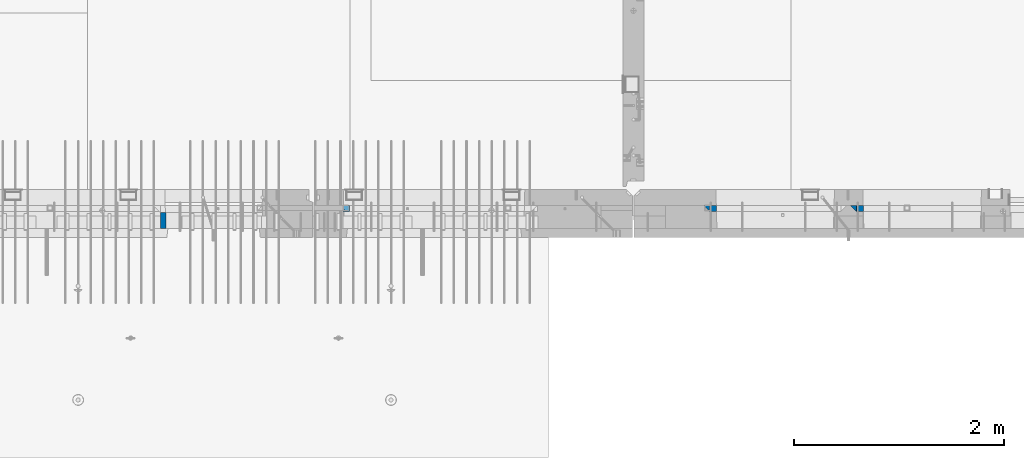
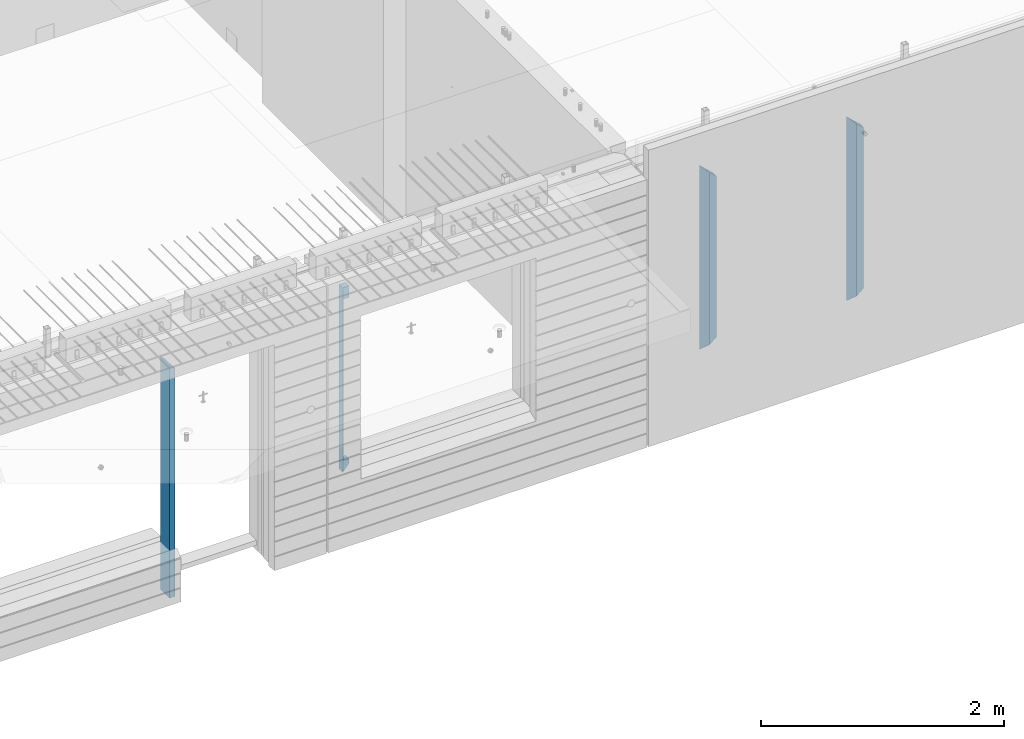
# One storey, part 3 of 309: 6 columns, 3 elements without a shape of their own.
"""IFC2X3 building model written with IfcOpenShell, lengths in millimetres."""

import ifcopenshell
import ifcopenshell.guid

model = None  # the IFC model being written
_history = None  # IfcOwnerHistory: only IFC2X3 demands one
_inside = {}  # id of a spatial element -> (the spatial element, [elements in it])
_under = {}  # id of a project, library or spatial element -> (it, [spatial elements below it])
_declared = {}  # id of a project -> (the project, [libraries it declares])
_typed = {}  # id of a type object -> (the type object, [elements of that type])
_made_of = {}  # id of a material, layer set ... -> (it, [elements and type objects made of it])


def new_model(schema):
    """Start an empty IFC model of exactly this schema.

    Asked for "IFC4X3", IfcOpenShell would pick the latest addendum, in which some entities
    have other attributes; the version numbers below select the first issue.
    IFC2X3 requires an IfcOwnerHistory on every rooted entity: one is made here for all.
    """
    global model, _history
    if schema == "IFC4X3":
        model = ifcopenshell.file(schema_version=(4, 3, 0, 0))
    else:
        model = ifcopenshell.file(schema=schema)
    _inside.clear()
    _under.clear()
    _declared.clear()
    _typed.clear()
    _made_of.clear()
    _history = None
    if model.schema == "IFC2X3":
        org = make("IfcOrganization", Name="unknown")
        user = make(
            "IfcPersonAndOrganization",
            ThePerson=make("IfcPerson", FamilyName="unknown"),
            TheOrganization=org,
        )
        app = make(
            "IfcApplication",
            ApplicationDeveloper=org,
            Version="unknown",
            ApplicationFullName="unknown",
            ApplicationIdentifier="unknown",
        )
        _history = make(
            "IfcOwnerHistory",
            OwningUser=user,
            OwningApplication=app,
            ChangeAction="ADDED",
            CreationDate=0,
        )
    return model


def make(cls, **values):
    """One entity of the class cls with the attributes given. An attribute that is None is left unset."""
    return model.create_entity(
        cls, **{name: value for name, value in values.items() if value is not None}
    )


def rooted(cls, **values):
    """An entity with a GlobalId (a new one), such as an element, a storey or a relation."""
    return make(cls, GlobalId=ifcopenshell.guid.new(), OwnerHistory=_history, **values)


def si_unit(unit_type, name, prefix=None):
    """IfcSIUnit, for example si_unit("LENGTHUNIT", "METRE", prefix="MILLI")."""
    return make("IfcSIUnit", UnitType=unit_type, Prefix=prefix, Name=name)


def assignment(units):
    """IfcUnitAssignment: the units of a project."""
    return None if units is None else make("IfcUnitAssignment", Units=units)


def point(xyz):
    """IfcCartesianPoint."""
    return None if xyz is None else make("IfcCartesianPoint", Coordinates=xyz)


def direction(xyz):
    """IfcDirection."""
    return None if xyz is None else make("IfcDirection", DirectionRatios=xyz)


def frame(location, z_axis=None, x_axis=None):
    """IfcAxis2Placement3D, a coordinate frame: its origin and axes. An axis left out is left unset."""
    return make(
        "IfcAxis2Placement3D",
        Location=point(location),
        Axis=direction(z_axis),
        RefDirection=direction(x_axis),
    )


def origin_with_axes():
    """The frame at (0, 0, 0) with the z axis (0, 0, 1) and the x axis (1, 0, 0) written out."""
    return frame((0.0, 0.0, 0.0), z_axis=(0.0, 0.0, 1.0), x_axis=(1.0, 0.0, 0.0))


def place(relative_to, where):
    """IfcLocalPlacement: puts the frame where relative to a parent placement (None: the world)."""
    return make(
        "IfcLocalPlacement", PlacementRelTo=relative_to, RelativePlacement=where
    )


def context(
    kind, dimensions, precision=None, world=None, true_north=None, identifier=None
):
    """IfcGeometricRepresentationContext, for example the 3D "Model" context."""
    return make(
        "IfcGeometricRepresentationContext",
        ContextIdentifier=identifier,
        ContextType=kind,
        CoordinateSpaceDimension=dimensions,
        Precision=precision,
        WorldCoordinateSystem=world,
        TrueNorth=true_north,
    )


def subcontext(parent, identifier, kind, view, scale=None):
    """IfcGeometricRepresentationSubContext, for example "Body" below "Model"."""
    return make(
        "IfcGeometricRepresentationSubContext",
        ContextIdentifier=identifier,
        ContextType=kind,
        ParentContext=parent,
        TargetScale=scale,
        TargetView=view,
    )


def project(units=None, contexts=None):
    """IfcProject with its units and contexts."""
    return rooted(
        "IfcProject",
        Name="project",
        RepresentationContexts=contexts,
        UnitsInContext=assignment(units),
    )


def spatial(cls, under=None, at=None, **own):
    """A site, building, storey or space (cls), placed at a placement, below another one or the project."""
    s = rooted(cls, ObjectPlacement=at, **own)
    if under is not None:
        _under.setdefault(under.id(), (under, []))[1].append(s)
    return s


def faces_of(points, faces, orient=None, outer=None):
    """IfcFace entities. A face is a list of loops; a loop is a list of indices into points, from 0.

    orient and outer hold one flag for each loop. By default every Orientation is true, the
    first loop of a face is its IfcFaceOuterBound and the others are IfcFaceBound.
    """
    made = []
    for i, loops in enumerate(faces):
        bounds = []
        for j, loop in enumerate(loops):
            is_outer = j == 0 if outer is None else outer[i][j]
            bounds.append(
                make(
                    "IfcFaceOuterBound" if is_outer else "IfcFaceBound",
                    Bound=make("IfcPolyLoop", Polygon=[points[k] for k in loop]),
                    Orientation=True if orient is None else orient[i][j],
                )
            )
        made.append(make("IfcFace", Bounds=bounds))
    return made


def faceted_brep(points, faces, orient=None, outer=None, voids=None):
    """IfcFacetedBrep: a solid bounded by flat faces; with voids (closed shells), ...WithVoids."""
    shared = [point(p) for p in points]
    hull = make("IfcClosedShell", CfsFaces=faces_of(shared, faces, orient, outer))
    if voids is None:
        return make("IfcFacetedBrep", Outer=hull)
    return make(
        "IfcFacetedBrepWithVoids",
        Outer=hull,
        Voids=[
            make(cls, CfsFaces=faces_of(shared, fs, o, b)) for cls, fs, o, b in voids
        ],
    )


def shape(context_of_items, identifier, shape_type, items):
    """IfcShapeRepresentation: the items that make up one representation, for example the "Body"."""
    return make(
        "IfcShapeRepresentation",
        ContextOfItems=context_of_items,
        RepresentationIdentifier=identifier,
        RepresentationType=shape_type,
        Items=items,
    )


def material(Name=None, Category=None):
    """IfcMaterial."""
    return make("IfcMaterial", Name=Name, Category=Category)


def made_of(thing, what):
    """Note that an element or type object is made of a material, layer set ...; save() writes the relation."""
    if what is not None:
        _made_of.setdefault(what.id(), (what, []))[1].append(thing)
    return thing


def type_object(cls, material=None, **own):
    """A type object (cls), such as IfcWallType, which elements share."""
    return made_of(rooted(cls, **own), material)


def element(
    cls,
    number,
    at=None,
    inside=None,
    cuts=None,
    type_object=None,
    material=None,
    context=None,
    identifier="Body",
    shape_type=None,
    held_by="IfcProductDefinitionShape",
    body=None,
    shapes=None,
    **own,
):
    """One element of the class cls, such as IfcWall. Its Tag is "e" and its number.

    at: its placement. inside: the storey or other place that contains it. cuts: it is an
    opening in that element (IfcRelVoidsElement). A single representation is given by context,
    identifier, shape_type and body (its items); several are given by shapes. held_by: the class
    of the entity that holds the representations. save() writes the other relations.
    """
    e = rooted(cls, Tag="e%d" % number, ObjectPlacement=at, **own)
    if body is not None:
        shapes = [shape(context, identifier, shape_type, body)]
    if shapes is not None:
        e.Representation = make(held_by, Representations=shapes)
    if inside is not None:
        _inside.setdefault(inside.id(), (inside, []))[1].append(e)
    if cuts is not None:
        rooted(
            "IfcRelVoidsElement", RelatingBuildingElement=cuts, RelatedOpeningElement=e
        )
    if type_object is not None:
        _typed.setdefault(type_object.id(), (type_object, []))[1].append(e)
    return made_of(e, material)


def aggregate(whole, parts):
    """IfcRelAggregates: a whole, such as a stair, and the parts it consists of."""
    return rooted("IfcRelAggregates", RelatingObject=whole, RelatedObjects=parts)


def save(model, path):
    """Write the relations noted so far, then the file.

    IfcRelAggregates (storeys below a building ...), IfcRelContainedInSpatialStructure (elements
    in a storey), IfcRelDefinesByType, IfcRelAssociatesMaterial and IfcRelDeclares: one each for
    every whole, place, type object, material and project.
    """
    for whole, parts in _under.values():
        aggregate(whole, parts)
    for where, things in _inside.values():
        rooted(
            "IfcRelContainedInSpatialStructure",
            RelatedElements=things,
            RelatingStructure=where,
        )
    for kind, things in _typed.values():
        rooted("IfcRelDefinesByType", RelatedObjects=things, RelatingType=kind)
    for what, things in _made_of.values():
        rooted("IfcRelAssociatesMaterial", RelatedObjects=things, RelatingMaterial=what)
    for by, libraries in _declared.values():
        rooted("IfcRelDeclares", RelatingContext=by, RelatedDefinitions=libraries)
    model.write(path)


model = new_model("IFC2X3")

# Units and contexts
model_context = context("Model", 3, precision=1e-05, world=origin_with_axes())
body_context = subcontext(model_context, "Body", "Model", "MODEL_VIEW")
ifc_project = project(units=[si_unit("LENGTHUNIT", "METRE", prefix="MILLI"), si_unit("AREAUNIT", "SQUARE_METRE"), si_unit("VOLUMEUNIT", "CUBIC_METRE"), si_unit("MASSUNIT", "GRAM", prefix="KILO"), si_unit("TIMEUNIT", "SECOND"), si_unit("PLANEANGLEUNIT", "RADIAN"), si_unit("SOLIDANGLEUNIT", "STERADIAN"), si_unit("THERMODYNAMICTEMPERATUREUNIT", "DEGREE_CELSIUS"), si_unit("LUMINOUSINTENSITYUNIT", "LUMEN")], contexts=[model_context])

# Site, building, storey
site_placement = place(None, origin_with_axes())
site = spatial("IfcSite", under=ifc_project, at=site_placement, CompositionType="ELEMENT")
building_placement = place(site_placement, origin_with_axes())
building = spatial("IfcBuilding", under=site, at=building_placement, CompositionType="ELEMENT")
storey_placement = place(building_placement, origin_with_axes())
storey = spatial("IfcBuildingStorey", under=building, at=storey_placement, Name="7", CompositionType="ELEMENT", Elevation=0.0)

# Assembly, column
assembly_1_placement = place(storey_placement, origin_with_axes())
assembly_1 = element("IfcElementAssembly", 1, at=assembly_1_placement, inside=storey, AssemblyPlace="NOTDEFINED", PredefinedType="REINFORCEMENT_UNIT")
ifc_material_1 = material(Name="TIMBER")
column_type_1 = type_object("IfcColumnType", Name="50X150", PredefinedType="NOTDEFINED")
column_1_placement = place(assembly_1_placement, frame((24129.9998642727, 7705.0, 99760.0), z_axis=(1.0, 0.0, 0.0), x_axis=(0.0, 0.0, 1.0)))
column_1 = element("IfcColumn", 2, at=column_1_placement, type_object=column_type_1, material=ifc_material_1, ObjectType="50X150", context=body_context, shape_type="Brep", body=[
    faceted_brep([(0.0, -75.0, -25.0), (1.81898940354586e-12, -75.0000000000009, 25.0), (1.81898940354586e-12, 75.0, 25.0), (0.0, 75.0, -25.0), (2295.00000000001, -75.0, 25.0), (2295.00000000001, 75.0, 25.0), (2345.0, 75.0, -25.0), (2345.0, -75.0, -25.0)], [[[0, 1, 2, 3]], [[2, 1, 4, 5]], [[3, 2, 5, 6]], [[0, 3, 6, 7]], [[1, 0, 7, 4]], [[6, 5, 4, 7]]]),
])
aggregate(assembly_1, [column_1])

assembly_2_placement = place(storey_placement, origin_with_axes())
assembly_2 = element("IfcElementAssembly", 3, at=assembly_2_placement, inside=storey, AssemblyPlace="NOTDEFINED", PredefinedType="REINFORCEMENT_UNIT")
ifc_material_2 = material(Name="CONCRETE/C35/45")
column_type_2 = type_object("IfcColumnType", PredefinedType="NOTDEFINED")
column_2_placement = place(assembly_2_placement, frame((25875.0006272121, 7820.0, 100320.0), z_axis=(1.0, 0.0, 0.0), x_axis=(0.0, 0.0, 1.0)))
column_2 = element("IfcColumn", 4, at=column_2_placement, type_object=column_type_2, material=ifc_material_2, Name="SK", context=body_context, shape_type="Brep", body=[
    faceted_brep([(1855.0, -30.0, 30.0), (1855.0, -30.0, -30.0), (1855.0, 30.0, -30.0), (1855.0, 30.0, 30.0), (1739.32432432432, 30.0, 30.0), (1740.94594594595, -30.0, 30.0), (1739.32432432432, 30.0, -24.3254687334993), (1740.94594594595, -30.0, -25.9470903551228), (115.67567567568, 30.0, -24.3254687334993), (114.054054054053, -30.0, -25.9470903551228), (114.054054054053, -30.0, 30.0), (115.67567567568, 30.0, 30.0), (72.2635272671032, -30.0, 30.0), (0.0, -30.0, -30.0), (0.0, 30.0, -30.0), (72.2635272671032, 30.0, 30.0)], [[[0, 1, 2, 3]], [[0, 3, 4, 5]], [[5, 4, 6, 7]], [[8, 9, 7, 6]], [[10, 9, 8, 11]], [[1, 0, 5, 7, 9, 10, 12, 13]], [[2, 1, 13, 14]], [[11, 8, 6, 4, 3, 2, 14, 15]], [[10, 11, 15, 12]], [[14, 13, 12, 15]]]),
])
aggregate(assembly_2, [column_2])

# Assembly, columns
assembly_3_placement = place(storey_placement, origin_with_axes())
assembly_3 = element("IfcElementAssembly", 5, at=assembly_3_placement, inside=storey, AssemblyPlace="NOTDEFINED", PredefinedType="REINFORCEMENT_UNIT")
column_3_placement = place(assembly_3_placement, frame((30704.9996552717, 7820.0, 100320.0), z_axis=(1.0, 0.0, 0.0), x_axis=(0.0, 0.0, 1.0)))
column_3 = element("IfcColumn", 6, at=column_3_placement, type_object=column_type_2, material=ifc_material_2, Name="SK", context=body_context, shape_type="Brep", body=[
    faceted_brep([(1795.00000000001, -30.0, 30.0), (1855.0, -30.0, -30.0), (1795.00000000001, 30.0, 30.0), (60.0000000000073, -30.0, 30.0), (0.0, -30.0, -30.0), (60.0000000000073, 30.0, 30.0)], [[[0, 1, 2]], [[1, 0, 3, 4]], [[2, 1, 4, 5]], [[0, 2, 5, 3]], [[5, 4, 3]]]),
])
column_4_placement = place(assembly_3_placement, frame((29305.0000367414, 7820.0, 100320.0), z_axis=(1.0, 0.0, 0.0), x_axis=(0.0, 0.0, 1.0)))
column_4 = element("IfcColumn", 7, at=column_4_placement, type_object=column_type_2, material=ifc_material_2, Name="SK", context=body_context, shape_type="Brep", body=[
    faceted_brep([(1795.00000000001, -30.0, 30.0), (1855.0, -30.0, -30.0), (1795.00000000001, 30.0, 30.0), (60.0000000000073, -30.0, 30.0), (0.0, -30.0, -30.0), (60.0000000000073, 30.0, 30.0)], [[[0, 1, 2]], [[1, 0, 3, 4]], [[2, 1, 4, 5]], [[0, 2, 5, 3]], [[5, 4, 3]]]),
])
column_type_3 = type_object("IfcColumnType", PredefinedType="NOTDEFINED")
column_5_placement = place(assembly_3_placement, frame((30769.9996552717, 7820.0, 100380.0), z_axis=(1.0, 0.0, 0.0), x_axis=(0.0, 0.0, 1.0)))
column_5 = element("IfcColumn", 8, at=column_5_placement, type_object=column_type_3, material=ifc_material_2, Name="SK", context=body_context, shape_type="Brep", body=[
    faceted_brep([(1678.70787161513, 29.999999998452, 30.6741497967687), (1680.09783300469, -29.999999998452, 29.0525281752307), (1735.0, -30.0, -35.0), (1735.0, 30.0, -35.0), (56.29212838487, 29.999999998452, 30.6741497967687), (54.9021669952926, -29.999999998452, 29.0525281752307), (0.0, -30.0, -35.0), (0.0, 30.0, -35.0)], [[[0, 1, 2, 3]], [[1, 0, 4, 5]], [[2, 1, 5, 6]], [[3, 2, 6, 7]], [[0, 3, 7, 4]], [[4, 7, 6, 5]]]),
])
column_6_placement = place(assembly_3_placement, frame((29370.0000367414, 7820.0, 100380.0), z_axis=(1.0, 0.0, 0.0), x_axis=(0.0, 0.0, 1.0)))
column_6 = element("IfcColumn", 9, at=column_6_placement, type_object=column_type_3, material=ifc_material_2, Name="SK", context=body_context, shape_type="Brep", body=[
    faceted_brep([(1735.0, -30.0, -35.0), (1735.0, 30.0, -35.0), (1678.70623674487, 30.0, 30.6760571454033), (1680.09619813452, -30.0, 29.0544355237798), (56.2937632551329, 29.9999988381387, 30.6760571454033), (54.9038019193104, -29.9999988381387, 29.0544355865859), (0.0, -30.0, -35.0), (0.0, 30.0, -35.0)], [[[0, 1, 2, 3]], [[3, 2, 4, 5]], [[0, 3, 5, 6]], [[1, 0, 6, 7]], [[2, 1, 7, 4]], [[5, 4, 7, 6]]]),
])
aggregate(assembly_3, [column_3, column_5, column_4, column_6])

save(model, "model.ifc")
